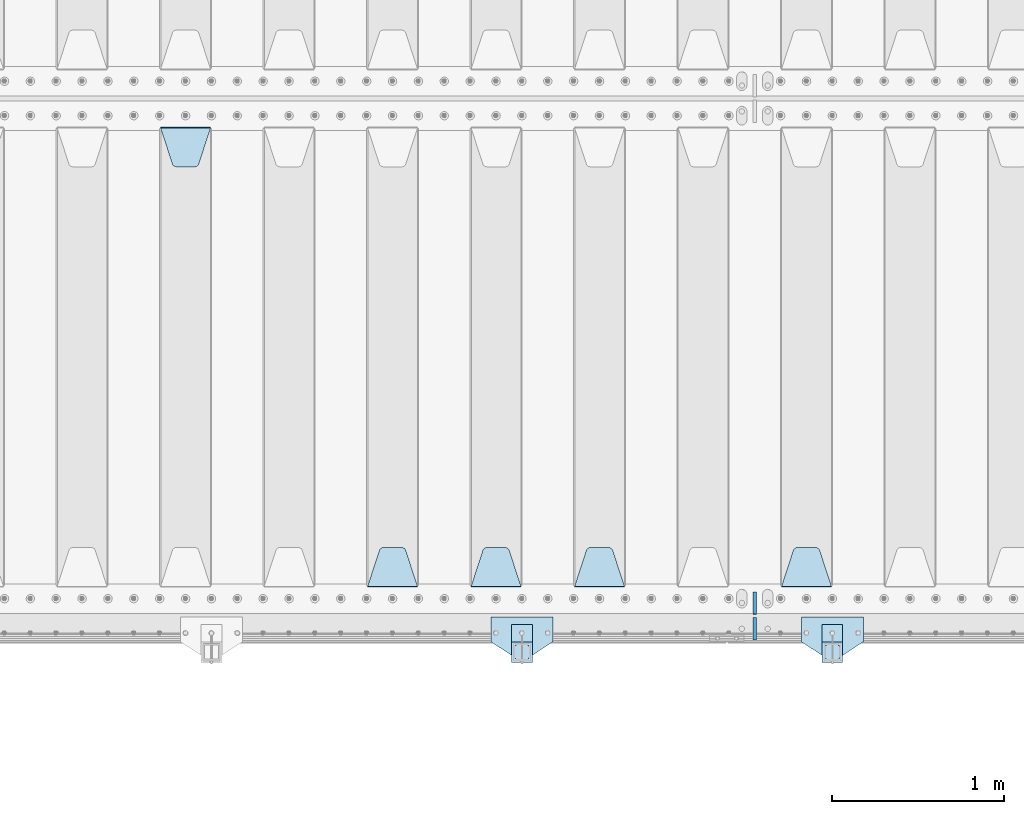
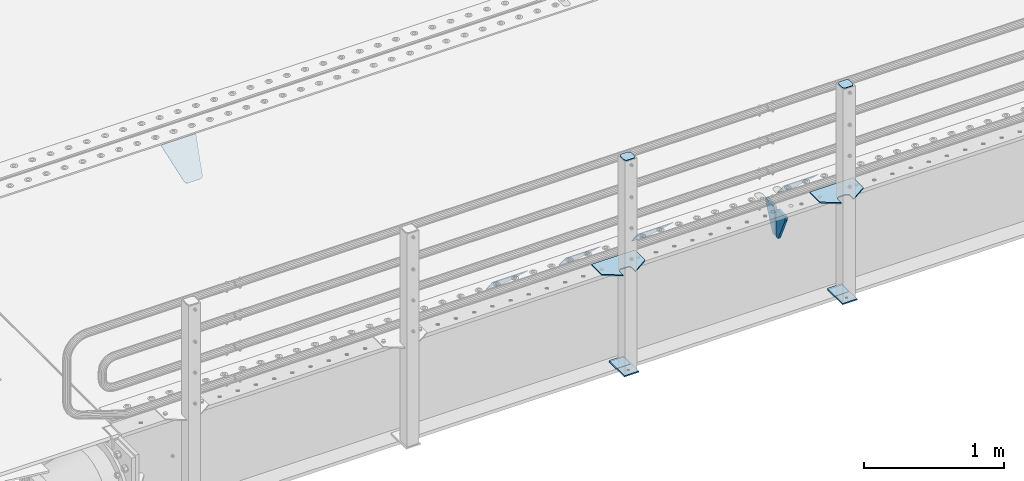
# One storey, part 198 of 247: 15 plates.
"""IFC2X3 building model written with IfcOpenShell, lengths in millimetres."""

from ifc_helpers import new_model, si_unit, frame, origin_with_axes, place, context, subcontext, project, spatial, faceted_brep, material, type_object, element, save


model = new_model("IFC2X3")

# Units and contexts
model_context = context("Model", 3, precision=1e-05, world=origin_with_axes())
body_context = subcontext(model_context, "Body", "Model", "MODEL_VIEW")
ifc_project = project(units=[si_unit("LENGTHUNIT", "METRE", prefix="MILLI"), si_unit("AREAUNIT", "SQUARE_METRE"), si_unit("VOLUMEUNIT", "CUBIC_METRE"), si_unit("MASSUNIT", "GRAM", prefix="KILO"), si_unit("TIMEUNIT", "SECOND"), si_unit("PLANEANGLEUNIT", "RADIAN"), si_unit("SOLIDANGLEUNIT", "STERADIAN"), si_unit("THERMODYNAMICTEMPERATUREUNIT", "DEGREE_CELSIUS"), si_unit("LUMINOUSINTENSITYUNIT", "LUMEN")], contexts=[model_context])

# Site, building, storey
site_placement = place(None, origin_with_axes())
site = spatial("IfcSite", under=ifc_project, at=site_placement, CompositionType="ELEMENT")
building_placement = place(site_placement, origin_with_axes())
building = spatial("IfcBuilding", under=site, at=building_placement, Name="Standard", CompositionType="ELEMENT")
storey_placement = place(building_placement, origin_with_axes())
storey = spatial("IfcBuildingStorey", under=building, at=storey_placement, Name="Undefined", CompositionType="ELEMENT", Elevation=0.0)

# Plates
ifc_material_1 = material(Name="STEEL/S355N")
plate_type_1 = type_object("IfcPlateType", PredefinedType="NOTDEFINED")
plate_1_placement = place(storey_placement, frame((5945.0, 168.232233047034, -1.76776695296758), z_axis=(0.0, 0.707106781186548, -0.707106781186547), x_axis=(-1.0, 0.0, 0.0)))
element("IfcPlate", 1, at=plate_1_placement, inside=storey, type_object=plate_type_1, material=ifc_material_1, context=body_context, shape_type="Brep", body=[
    faceted_brep([(0.0, -2.49999999999909, 0.0), (69.345504679477, -2.5, 300.17173142483), (69.345504679477, 2.50000000000091, 300.171731424831), (0.0, 2.5, -9.09494701772928e-13), (70.9274061199576, -2.5, 304.897442415399), (70.9274061199576, 2.50000000000091, 304.8974424154), (73.3818627772307, -2.49999999999909, 309.234538108527), (73.3818627772307, 2.5, 309.234538108526), (76.6187032999551, -2.5, 313.023683126102), (76.6187032999551, 2.50000000000091, 313.023683126102), (80.5190132704993, -2.49999999999909, 316.125672595371), (80.5190132704993, 2.50000000000091, 316.125672595372), (84.9395038596849, -2.49999999999909, 318.426546230476), (84.9395038596849, 2.5, 318.426546230475), (89.7177759439219, -2.5, 319.841774983274), (89.7177759439219, 2.50000000000091, 319.841774983275), (94.678286292652, -2.5, 320.319366455077), (94.678286292652, 2.50000000000091, 320.319366455077), (195.321713707348, -2.5, 320.319366455077), (195.321713707348, 2.50000000000091, 320.319366455077), (200.282224056078, -2.5, 319.841774983274), (200.282224056078, 2.50000000000091, 319.841774983275), (205.060496140315, -2.5, 318.426546230475), (205.060496140315, 2.5, 318.426546230474), (209.480986729501, -2.49999999999818, 316.12567259537), (209.480986729501, 2.50000000000091, 316.12567259537), (213.381296700045, -2.5, 313.023683126101), (213.381296700045, 2.50000000000091, 313.023683126101), (216.618137222769, -2.5, 309.234538108525), (216.618137222769, 2.5, 309.234538108525), (219.072593880042, -2.49999999999909, 304.897442415398), (219.072593880042, 2.5, 304.897442415398), (220.654495320523, -2.5, 300.17173142483), (220.654495320523, 2.50000000000091, 300.171731424831), (290.0, -2.49999999999909, 0.0), (290.0, 2.5, -9.09494701772928e-13)], [[[0, 1, 2, 3]], [[1, 4, 5, 2]], [[4, 6, 7, 5]], [[6, 8, 9, 7]], [[8, 10, 11, 9]], [[10, 12, 13, 11]], [[12, 14, 15, 13]], [[14, 16, 17, 15]], [[16, 18, 19, 17]], [[18, 20, 21, 19]], [[20, 22, 23, 21]], [[22, 24, 25, 23]], [[24, 26, 27, 25]], [[26, 28, 29, 27]], [[28, 30, 31, 29]], [[30, 32, 33, 31]], [[32, 34, 35, 33]], [[34, 0, 3, 35]], [[5, 7, 9, 11, 13, 15, 17, 19, 21, 23, 25, 27, 29, 31, 33, 35, 3, 2]], [[34, 32, 30, 28, 26, 24, 22, 20, 18, 16, 14, 12, 10, 8, 6, 4, 1, 0]]]),
])
plate_2_placement = place(storey_placement, frame((4745.0, 168.232233047034, -1.76776695296758), z_axis=(0.0, 0.707106781186548, -0.707106781186547), x_axis=(-1.0, 0.0, 0.0)))
element("IfcPlate", 2, at=plate_2_placement, inside=storey, type_object=plate_type_1, material=ifc_material_1, context=body_context, shape_type="Brep", body=[
    faceted_brep([(0.0, -2.49999999999909, 0.0), (69.345504679477, -2.5, 300.17173142483), (69.345504679477, 2.50000000000091, 300.171731424831), (0.0, 2.5, -9.09494701772928e-13), (70.9274061199576, -2.5, 304.897442415399), (70.9274061199576, 2.50000000000091, 304.8974424154), (73.3818627772307, -2.49999999999909, 309.234538108527), (73.3818627772307, 2.5, 309.234538108526), (76.6187032999551, -2.5, 313.023683126102), (76.6187032999551, 2.50000000000091, 313.023683126102), (80.5190132704993, -2.49999999999909, 316.125672595371), (80.5190132704993, 2.50000000000091, 316.125672595372), (84.9395038596849, -2.49999999999909, 318.426546230476), (84.9395038596849, 2.5, 318.426546230475), (89.7177759439219, -2.5, 319.841774983274), (89.7177759439219, 2.50000000000091, 319.841774983275), (94.678286292652, -2.5, 320.319366455077), (94.678286292652, 2.50000000000091, 320.319366455077), (195.321713707348, -2.5, 320.319366455077), (195.321713707348, 2.50000000000091, 320.319366455077), (200.282224056078, -2.5, 319.841774983274), (200.282224056078, 2.50000000000091, 319.841774983275), (205.060496140315, -2.5, 318.426546230475), (205.060496140315, 2.5, 318.426546230474), (209.480986729501, -2.49999999999818, 316.12567259537), (209.480986729501, 2.50000000000091, 316.12567259537), (213.381296700045, -2.5, 313.023683126101), (213.381296700045, 2.50000000000091, 313.023683126101), (216.618137222769, -2.5, 309.234538108525), (216.618137222769, 2.5, 309.234538108525), (219.072593880042, -2.49999999999909, 304.897442415398), (219.072593880042, 2.5, 304.897442415398), (220.654495320523, -2.5, 300.17173142483), (220.654495320523, 2.50000000000091, 300.171731424831), (290.0, -2.49999999999909, 0.0), (290.0, 2.5, -9.09494701772928e-13)], [[[0, 1, 2, 3]], [[1, 4, 5, 2]], [[4, 6, 7, 5]], [[6, 8, 9, 7]], [[8, 10, 11, 9]], [[10, 12, 13, 11]], [[12, 14, 15, 13]], [[14, 16, 17, 15]], [[16, 18, 19, 17]], [[18, 20, 21, 19]], [[20, 22, 23, 21]], [[22, 24, 25, 23]], [[24, 26, 27, 25]], [[26, 28, 29, 27]], [[28, 30, 31, 29]], [[30, 32, 33, 31]], [[32, 34, 35, 33]], [[34, 0, 3, 35]], [[5, 7, 9, 11, 13, 15, 17, 19, 21, 23, 25, 27, 29, 31, 33, 35, 3, 2]], [[34, 32, 30, 28, 26, 24, 22, 20, 18, 16, 14, 12, 10, 8, 6, 4, 1, 0]]]),
])
plate_3_placement = place(storey_placement, frame((4145.0, 168.232233047034, -1.76776695296758), z_axis=(0.0, 0.707106781186548, -0.707106781186547), x_axis=(-1.0, 0.0, 0.0)))
element("IfcPlate", 3, at=plate_3_placement, inside=storey, type_object=plate_type_1, material=ifc_material_1, context=body_context, shape_type="Brep", body=[
    faceted_brep([(0.0, -2.49999999999909, 0.0), (69.345504679477, -2.5, 300.17173142483), (69.345504679477, 2.50000000000091, 300.171731424831), (0.0, 2.5, -9.09494701772928e-13), (70.9274061199576, -2.5, 304.897442415399), (70.9274061199576, 2.50000000000091, 304.8974424154), (73.3818627772307, -2.49999999999909, 309.234538108527), (73.3818627772307, 2.5, 309.234538108526), (76.6187032999551, -2.5, 313.023683126102), (76.6187032999551, 2.50000000000091, 313.023683126102), (80.5190132704993, -2.49999999999909, 316.125672595371), (80.5190132704993, 2.50000000000091, 316.125672595372), (84.9395038596849, -2.49999999999909, 318.426546230476), (84.9395038596849, 2.5, 318.426546230475), (89.7177759439219, -2.5, 319.841774983274), (89.7177759439219, 2.50000000000091, 319.841774983275), (94.678286292652, -2.5, 320.319366455077), (94.678286292652, 2.50000000000091, 320.319366455077), (195.321713707348, -2.5, 320.319366455077), (195.321713707348, 2.50000000000091, 320.319366455077), (200.282224056078, -2.5, 319.841774983274), (200.282224056078, 2.50000000000091, 319.841774983275), (205.060496140315, -2.5, 318.426546230475), (205.060496140315, 2.5, 318.426546230474), (209.480986729501, -2.49999999999818, 316.12567259537), (209.480986729501, 2.50000000000091, 316.12567259537), (213.381296700045, -2.5, 313.023683126101), (213.381296700045, 2.50000000000091, 313.023683126101), (216.618137222769, -2.5, 309.234538108525), (216.618137222769, 2.5, 309.234538108525), (219.072593880042, -2.49999999999909, 304.897442415398), (219.072593880042, 2.5, 304.897442415398), (220.654495320523, -2.5, 300.17173142483), (220.654495320523, 2.50000000000091, 300.171731424831), (290.0, -2.49999999999909, 0.0), (290.0, 2.5, -9.09494701772928e-13)], [[[0, 1, 2, 3]], [[1, 4, 5, 2]], [[4, 6, 7, 5]], [[6, 8, 9, 7]], [[8, 10, 11, 9]], [[10, 12, 13, 11]], [[12, 14, 15, 13]], [[14, 16, 17, 15]], [[16, 18, 19, 17]], [[18, 20, 21, 19]], [[20, 22, 23, 21]], [[22, 24, 25, 23]], [[24, 26, 27, 25]], [[26, 28, 29, 27]], [[28, 30, 31, 29]], [[30, 32, 33, 31]], [[32, 34, 35, 33]], [[34, 0, 3, 35]], [[5, 7, 9, 11, 13, 15, 17, 19, 21, 23, 25, 27, 29, 31, 33, 35, 3, 2]], [[34, 32, 30, 28, 26, 24, 22, 20, 18, 16, 14, 12, 10, 8, 6, 4, 1, 0]]]),
])
plate_4_placement = place(storey_placement, frame((3545.0, 168.232233047034, -1.76776695296758), z_axis=(0.0, 0.707106781186548, -0.707106781186547), x_axis=(-1.0, 0.0, 0.0)))
element("IfcPlate", 4, at=plate_4_placement, inside=storey, type_object=plate_type_1, material=ifc_material_1, context=body_context, shape_type="Brep", body=[
    faceted_brep([(0.0, -2.49999999999909, 0.0), (69.345504679477, -2.5, 300.17173142483), (69.345504679477, 2.50000000000091, 300.171731424831), (0.0, 2.5, -9.09494701772928e-13), (70.9274061199576, -2.5, 304.897442415399), (70.9274061199576, 2.50000000000091, 304.8974424154), (73.3818627772307, -2.49999999999909, 309.234538108527), (73.3818627772307, 2.5, 309.234538108526), (76.6187032999551, -2.5, 313.023683126102), (76.6187032999551, 2.50000000000091, 313.023683126102), (80.5190132704993, -2.49999999999909, 316.125672595371), (80.5190132704993, 2.50000000000091, 316.125672595372), (84.9395038596849, -2.49999999999909, 318.426546230476), (84.9395038596849, 2.5, 318.426546230475), (89.7177759439219, -2.5, 319.841774983274), (89.7177759439219, 2.50000000000091, 319.841774983275), (94.678286292652, -2.5, 320.319366455077), (94.678286292652, 2.50000000000091, 320.319366455077), (195.321713707348, -2.5, 320.319366455077), (195.321713707348, 2.50000000000091, 320.319366455077), (200.282224056078, -2.5, 319.841774983274), (200.282224056078, 2.50000000000091, 319.841774983275), (205.060496140315, -2.5, 318.426546230475), (205.060496140315, 2.5, 318.426546230474), (209.480986729501, -2.49999999999818, 316.12567259537), (209.480986729501, 2.50000000000091, 316.12567259537), (213.381296700045, -2.5, 313.023683126101), (213.381296700045, 2.50000000000091, 313.023683126101), (216.618137222769, -2.5, 309.234538108525), (216.618137222769, 2.5, 309.234538108525), (219.072593880042, -2.49999999999909, 304.897442415398), (219.072593880042, 2.5, 304.897442415398), (220.654495320523, -2.5, 300.17173142483), (220.654495320523, 2.50000000000091, 300.171731424831), (290.0, -2.49999999999909, 0.0), (290.0, 2.5, -9.09494701772928e-13)], [[[0, 1, 2, 3]], [[1, 4, 5, 2]], [[4, 6, 7, 5]], [[6, 8, 9, 7]], [[8, 10, 11, 9]], [[10, 12, 13, 11]], [[12, 14, 15, 13]], [[14, 16, 17, 15]], [[16, 18, 19, 17]], [[18, 20, 21, 19]], [[20, 22, 23, 21]], [[22, 24, 25, 23]], [[24, 26, 27, 25]], [[26, 28, 29, 27]], [[28, 30, 31, 29]], [[30, 32, 33, 31]], [[32, 34, 35, 33]], [[34, 0, 3, 35]], [[5, 7, 9, 11, 13, 15, 17, 19, 21, 23, 25, 27, 29, 31, 33, 35, 3, 2]], [[34, 32, 30, 28, 26, 24, 22, 20, 18, 16, 14, 12, 10, 8, 6, 4, 1, 0]]]),
])
plate_5_placement = place(storey_placement, frame((2055.0, 2831.76776695594, -1.767766952965), z_axis=(0.0, -0.707106781186548, -0.707106781186547), x_axis=(1.0, 0.0, 0.0)))
element("IfcPlate", 5, at=plate_5_placement, inside=storey, type_object=plate_type_1, material=ifc_material_1, context=body_context, shape_type="Brep", body=[
    faceted_brep([(0.0, -2.49999999999909, 0.0), (69.345504679477, -2.5, 300.17173142483), (69.345504679477, 2.50000000000091, 300.171731424831), (0.0, 2.5, -9.09494701772928e-13), (70.9274061199576, -2.5, 304.897442415399), (70.9274061199576, 2.50000000000091, 304.8974424154), (73.3818627772307, -2.49999999999909, 309.234538108527), (73.3818627772307, 2.5, 309.234538108526), (76.6187032999551, -2.5, 313.023683126102), (76.6187032999551, 2.50000000000091, 313.023683126102), (80.5190132704993, -2.49999999999909, 316.125672595371), (80.5190132704993, 2.50000000000091, 316.125672595372), (84.9395038596849, -2.49999999999909, 318.426546230476), (84.9395038596849, 2.5, 318.426546230475), (89.7177759439219, -2.5, 319.841774983274), (89.7177759439219, 2.50000000000091, 319.841774983275), (94.678286292652, -2.5, 320.319366455077), (94.678286292652, 2.50000000000091, 320.319366455077), (195.321713707348, -2.5, 320.319366455077), (195.321713707348, 2.50000000000091, 320.319366455077), (200.282224056078, -2.5, 319.841774983274), (200.282224056078, 2.50000000000091, 319.841774983275), (205.060496140315, -2.5, 318.426546230475), (205.060496140315, 2.5, 318.426546230474), (209.480986729501, -2.49999999999818, 316.12567259537), (209.480986729501, 2.50000000000091, 316.12567259537), (213.381296700045, -2.5, 313.023683126101), (213.381296700045, 2.50000000000091, 313.023683126101), (216.618137222769, -2.5, 309.234538108525), (216.618137222769, 2.5, 309.234538108525), (219.072593880042, -2.49999999999909, 304.897442415398), (219.072593880042, 2.5, 304.897442415398), (220.654495320523, -2.5, 300.17173142483), (220.654495320523, 2.50000000000091, 300.171731424831), (290.0, -2.49999999999909, 0.0), (290.0, 2.5, -9.09494701772928e-13)], [[[0, 1, 2, 3]], [[1, 4, 5, 2]], [[4, 6, 7, 5]], [[6, 8, 9, 7]], [[8, 10, 11, 9]], [[10, 12, 13, 11]], [[12, 14, 15, 13]], [[14, 16, 17, 15]], [[16, 18, 19, 17]], [[18, 20, 21, 19]], [[20, 22, 23, 21]], [[22, 24, 25, 23]], [[24, 26, 27, 25]], [[26, 28, 29, 27]], [[28, 30, 31, 29]], [[30, 32, 33, 31]], [[32, 34, 35, 33]], [[34, 0, 3, 35]], [[5, 7, 9, 11, 13, 15, 17, 19, 21, 23, 25, 27, 29, 31, 33, 35, 3, 2]], [[34, 32, 30, 28, 26, 24, 22, 20, 18, 16, 14, 12, 10, 8, 6, 4, 1, 0]]]),
])
plate_type_2 = type_object("IfcPlateType", PredefinedType="NOTDEFINED")
for number, where, z_axis, x_axis in (
    (6, (5500.0, 140.0, -30.0), (0.0, 0.0, -1.0), (0.0, -0.999999999999548, -9.5100000000016e-07)),
    (7, (5500.0, -140.0, -30.0), (0.0, 0.0, -1.0), (0.0, 1.0, 0.0)),
):
    element("IfcPlate", number, at=place(storey_placement, frame(where, z_axis=z_axis, x_axis=x_axis)), inside=storey, type_object=plate_type_2, material=ifc_material_1, context=body_context, shape_type="Brep", body=[
        faceted_brep([(-5.6843418860808e-14, -9.99999999999989, 3.5527136788005e-15), (0.0, -10.0, 30.0), (0.0, 10.0, 30.0), (-5.6843418860808e-14, 10.0000000000001, 3.5527136788005e-15), (102.0, -10.0, 250.0), (102.0, 10.0, 250.0), (132.0, -10.0, 250.0), (132.0, 10.0, 250.0), (132.0, -10.0, 30.0), (132.0, 10.0, 30.0), (131.544232590366, -10.0, 24.790554669992), (131.544232590366, 10.0, 24.790554669992), (130.190778623577, -10.0, 19.7393957002299), (130.190778623577, 10.0, 19.7393957002299), (127.980762113533, -10.0, 15.0), (127.980762113533, 10.0, 15.0), (124.981333293569, -10.0, 10.7163717094038), (124.981333293569, 10.0, 10.7163717094038), (121.283628290596, -10.0, 7.01866670643062), (121.283628290596, 10.0, 7.01866670643062), (117.0, -10.0, 4.01923788646684), (117.0, 10.0, 4.01923788646684), (112.26060429977, -10.0, 1.80922137642278), (112.26060429977, 10.0, 1.80922137642278), (107.209445330008, -10.0, 0.455767409633722), (107.209445330008, 10.0, 0.455767409633722), (102.0, -10.0, 0.0), (102.0, 10.0, 0.0)], [[[0, 1, 2, 3]], [[1, 4, 5, 2]], [[4, 6, 7, 5]], [[6, 8, 9, 7]], [[8, 10, 11, 9]], [[10, 12, 13, 11]], [[12, 14, 15, 13]], [[14, 16, 17, 15]], [[16, 18, 19, 17]], [[18, 20, 21, 19]], [[20, 22, 23, 21]], [[22, 24, 25, 23]], [[24, 26, 27, 25]], [[26, 0, 3, 27]], [[5, 7, 9, 11, 13, 15, 17, 19, 21, 23, 25, 27, 3, 2]], [[26, 24, 22, 20, 18, 16, 14, 12, 10, 8, 6, 4, 1, 0]]]),
    ])
ifc_material_2 = material(Name="STEEL/S355J2")
plate_type_3 = type_object("IfcPlateType", PredefinedType="NOTDEFINED")
plate_6_placement = place(storey_placement, frame((6130.0, -4.99999999999636, 5.00000000004911), z_axis=(0.0, -0.999999999999548, -9.5100000000016e-07), x_axis=(-1.0, 0.0, 0.0)))
element("IfcPlate", 8, at=plate_6_placement, inside=storey, type_object=plate_type_3, material=ifc_material_2, context=body_context, shape_type="Brep", body=[
    faceted_brep([(9.04219632502645e-09, -5.00000000143385, -2.89173840428703e-09), (2.31396552408114e-06, -5.0, 145.0), (2.31396552408114e-06, 5.0, 145.0), (7.66340235713869e-09, 4.99999999856618, -2.89173840428703e-09), (130.0, -5.0, 230.0), (130.0, 5.0, 230.0), (130.0, -5.0, 180.0), (130.0, 5.0, 180.0), (130.48036798992, -5.0, 175.122741949597), (130.48036798992, 5.0, 175.122741949597), (131.903011687218, -5.0, 170.432914190873), (131.903011687218, 5.0, 170.432914190873), (134.213259692437, -5.0, 166.11074417451), (134.213259692437, 5.0, 166.11074417451), (137.322330470337, -5.0, 162.322330470337), (137.322330470337, 5.0, 162.322330470337), (141.11074417451, -5.0, 159.213259692437), (141.11074417451, 5.0, 159.213259692437), (145.432914190873, -5.0, 156.903011687218), (145.432914190873, 5.0, 156.903011687218), (150.122741949597, -5.0, 155.48036798992), (150.122741949597, 5.0, 155.48036798992), (155.0, -5.0, 155.0), (155.0, 5.0, 155.0), (205.0, -5.0, 155.0), (205.0, 5.0, 155.0), (209.877258050403, -5.0, 155.48036798992), (209.877258050403, 5.0, 155.48036798992), (214.567085809127, -5.0, 156.903011687218), (214.567085809127, 5.0, 156.903011687218), (218.88925582549, -5.0, 159.213259692437), (218.88925582549, 5.0, 159.213259692437), (222.677669529663, -5.0, 162.322330470337), (222.677669529663, 5.0, 162.322330470337), (225.786740307563, -5.0, 166.11074417451), (225.786740307563, 5.0, 166.11074417451), (228.096988312782, -5.0, 170.432914190873), (228.096988312782, 5.0, 170.432914190873), (229.51963201008, -5.0, 175.122741949597), (229.51963201008, 5.0, 175.122741949597), (230.0, -5.0, 180.0), (230.0, 5.0, 180.0), (230.0, -5.0, 230.0), (230.0, 5.0, 230.0), (360.0, -5.0, 145.0), (360.0, 5.0, 145.0), (360.0, -5.0, -7.27595761418343e-12), (360.0, 5.0, -7.27595761418343e-12)], [[[0, 1, 2, 3]], [[1, 4, 5, 2]], [[4, 6, 7, 5]], [[6, 8, 9, 7]], [[8, 10, 11, 9]], [[10, 12, 13, 11]], [[12, 14, 15, 13]], [[14, 16, 17, 15]], [[16, 18, 19, 17]], [[18, 20, 21, 19]], [[20, 22, 23, 21]], [[22, 24, 25, 23]], [[24, 26, 27, 25]], [[26, 28, 29, 27]], [[28, 30, 31, 29]], [[30, 32, 33, 31]], [[32, 34, 35, 33]], [[34, 36, 37, 35]], [[36, 38, 39, 37]], [[38, 40, 41, 39]], [[40, 42, 43, 41]], [[42, 44, 45, 43]], [[44, 46, 47, 45]], [[46, 0, 3, 47]], [[5, 7, 9, 11, 13, 15, 17, 19, 21, 23, 25, 27, 29, 31, 33, 35, 37, 39, 41, 43, 45, 47, 3, 2]], [[46, 44, 42, 40, 38, 36, 34, 32, 30, 28, 26, 24, 22, 20, 18, 16, 14, 12, 10, 8, 6, 4, 1, 0]]]),
])
plate_7_placement = place(storey_placement, frame((4330.0, -4.99999999999636, 5.00000000004911), z_axis=(0.0, -0.999999999999548, -9.5100000000016e-07), x_axis=(-1.0, 0.0, 0.0)))
element("IfcPlate", 9, at=plate_7_placement, inside=storey, type_object=plate_type_3, material=ifc_material_2, context=body_context, shape_type="Brep", body=[
    faceted_brep([(9.04219632502645e-09, -5.00000000143385, -2.89173840428703e-09), (2.31396552408114e-06, -5.0, 145.0), (2.31396552408114e-06, 5.0, 145.0), (7.66340235713869e-09, 4.99999999856618, -2.89173840428703e-09), (130.0, -5.0, 230.0), (130.0, 5.0, 230.0), (130.0, -5.0, 180.0), (130.0, 5.0, 180.0), (130.48036798992, -5.0, 175.122741949597), (130.48036798992, 5.0, 175.122741949597), (131.903011687218, -5.0, 170.432914190873), (131.903011687218, 5.0, 170.432914190873), (134.213259692437, -5.0, 166.11074417451), (134.213259692437, 5.0, 166.11074417451), (137.322330470337, -5.0, 162.322330470337), (137.322330470337, 5.0, 162.322330470337), (141.11074417451, -5.0, 159.213259692437), (141.11074417451, 5.0, 159.213259692437), (145.432914190873, -5.0, 156.903011687218), (145.432914190873, 5.0, 156.903011687218), (150.122741949597, -5.0, 155.48036798992), (150.122741949597, 5.0, 155.48036798992), (155.0, -5.0, 155.0), (155.0, 5.0, 155.0), (205.0, -5.0, 155.0), (205.0, 5.0, 155.0), (209.877258050403, -5.0, 155.48036798992), (209.877258050403, 5.0, 155.48036798992), (214.567085809127, -5.0, 156.903011687218), (214.567085809127, 5.0, 156.903011687218), (218.88925582549, -5.0, 159.213259692437), (218.88925582549, 5.0, 159.213259692437), (222.677669529663, -5.0, 162.322330470337), (222.677669529663, 5.0, 162.322330470337), (225.786740307563, -5.0, 166.11074417451), (225.786740307563, 5.0, 166.11074417451), (228.096988312782, -5.0, 170.432914190873), (228.096988312782, 5.0, 170.432914190873), (229.51963201008, -5.0, 175.122741949597), (229.51963201008, 5.0, 175.122741949597), (230.0, -5.0, 180.0), (230.0, 5.0, 180.0), (230.0, -5.0, 230.0), (230.0, 5.0, 230.0), (360.0, -5.0, 145.0), (360.0, 5.0, 145.0), (360.0, -5.0, -7.27595761418343e-12), (360.0, 5.0, -7.27595761418343e-12)], [[[0, 1, 2, 3]], [[1, 4, 5, 2]], [[4, 6, 7, 5]], [[6, 8, 9, 7]], [[8, 10, 11, 9]], [[10, 12, 13, 11]], [[12, 14, 15, 13]], [[14, 16, 17, 15]], [[16, 18, 19, 17]], [[18, 20, 21, 19]], [[20, 22, 23, 21]], [[22, 24, 25, 23]], [[24, 26, 27, 25]], [[26, 28, 29, 27]], [[28, 30, 31, 29]], [[30, 32, 33, 31]], [[32, 34, 35, 33]], [[34, 36, 37, 35]], [[36, 38, 39, 37]], [[38, 40, 41, 39]], [[40, 42, 43, 41]], [[42, 44, 45, 43]], [[44, 46, 47, 45]], [[46, 0, 3, 47]], [[5, 7, 9, 11, 13, 15, 17, 19, 21, 23, 25, 27, 29, 31, 33, 35, 37, 39, 41, 43, 45, 47, 3, 2]], [[46, 44, 42, 40, 38, 36, 34, 32, 30, 28, 26, 24, 22, 20, 18, 16, 14, 12, 10, 8, 6, 4, 1, 0]]]),
])
plate_type_4 = type_object("IfcPlateType", PredefinedType="NOTDEFINED")
for number, where, z_axis, x_axis in (
    (10, (6009.99999999986, -50.0000000002074, -850.000000000002), (0.0, -0.999999999999548, -9.5100000000016e-07), (-1.0, 0.0, 0.0)),
    (11, (4209.99999999986, -50.0000000002074, -850.000000000002), (0.0, -0.999999999999548, -9.5100000000016e-07), (-1.0, 0.0, 0.0)),
):
    element("IfcPlate", number, at=place(storey_placement, frame(where, z_axis=z_axis, x_axis=x_axis)), inside=storey, type_object=plate_type_4, material=ifc_material_2, context=body_context, shape_type="Brep", body=[
        faceted_brep([(53.6360389691836, -5.0, 176.363961030469), (53.6360389691836, 5.0, 176.363961030469), (59.9999999998618, 5.0, 178.999999999791), (59.9999999998618, -5.0, 178.999999999791), (66.3639610305399, 5.0, 176.363961030469), (66.3639610305399, -5.0, 176.363961030469), (68.9999999998618, 5.0, 169.999999999791), (68.9999999998618, -5.0, 169.999999999791), (66.3639610305399, 5.0, 163.636038969113), (66.3639610305399, -5.0, 163.636038969113), (59.9999999998618, 5.0, 160.999999999791), (59.9999999998618, -5.0, 160.999999999791), (53.6360389691836, 5.0, 163.636038969113), (53.6360389691836, -5.0, 163.636038969113), (50.9999999998618, 5.0, 169.999999999791), (50.9999999998618, -5.0, 169.999999999791), (120.0, -5.0, 0.0), (120.0, -5.0, 220.0), (0.0, -5.0, 220.0), (9.04219632502645e-09, -5.00000000143385, -2.89173840428703e-09), (7.66340235713869e-09, 4.99999999856618, -2.89173840428703e-09), (120.0, 5.0, 0.0), (120.0, 5.0, 220.0), (0.0, 5.0, 220.0)], [[[0, 1, 2, 3]], [[3, 2, 4, 5]], [[5, 4, 6, 7]], [[7, 6, 8, 9]], [[9, 8, 10, 11]], [[11, 10, 12, 13]], [[13, 12, 14, 15]], [[15, 14, 1, 0]], [[16, 17, 18, 19], [11, 13, 15, 0, 3, 5, 7, 9]], [[16, 19, 20, 21]], [[17, 16, 21, 22]], [[18, 17, 22, 23]], [[19, 18, 23, 20]], [[22, 21, 20, 23], [2, 1, 14, 12, 10, 8, 6, 4]]]),
    ])
plate_type_5 = type_object("IfcPlateType", PredefinedType="NOTDEFINED")
plate_8_placement = place(storey_placement, frame((5905.99999999987, -166.000000000207, 1012.50000000001), z_axis=(0.0, -0.999999999999548, -9.5100000000016e-07), x_axis=(1.0, 0.0, 0.0)))
element("IfcPlate", 12, at=plate_8_placement, inside=storey, type_object=plate_type_5, material=ifc_material_2, context=body_context, shape_type="Brep", body=[
    faceted_brep([(0.0, -2.5, 19.0), (0.0, -2.5, 69.0), (0.0, 2.5, 69.0), (0.0, 2.5, 19.0), (0.476369668545885, -2.5, 73.2278977451697), (0.476369668545885, 2.5, 73.2278977451697), (1.88159150985484, -2.5, 77.2437910432327), (1.88159150985484, 2.5, 77.2437910432327), (4.14520183310742, -2.5, 80.8463062353167), (4.14520183310742, 2.5, 80.8463062353167), (7.15369376468334, -2.5, 83.8547981668926), (7.15369376468334, 2.5, 83.8547981668926), (10.7562089567673, -2.5, 86.1184084901452), (10.7562089567673, 2.5, 86.1184084901452), (14.7721022548303, -2.5, 87.5236303314541), (14.7721022548303, 2.5, 87.5236303314541), (19.0, -2.5, 88.0), (19.0, 2.5, 88.0), (69.0, -2.5, 88.0), (69.0, 2.5, 88.0), (73.2278977451697, -2.5, 87.5236303314541), (73.2278977451697, 2.5, 87.5236303314541), (77.2437910432327, -2.5, 86.1184084901452), (77.2437910432327, 2.5, 86.1184084901452), (80.8463062353167, -2.5, 83.8547981668926), (80.8463062353167, 2.5, 83.8547981668926), (83.8547981668926, -2.5, 80.8463062353167), (83.8547981668926, 2.5, 80.8463062353167), (86.1184084901452, -2.5, 77.2437910432327), (86.1184084901452, 2.5, 77.2437910432327), (87.5236303314541, -2.5, 73.2278977451697), (87.5236303314541, 2.5, 73.2278977451697), (88.0, -2.5, 69.0), (88.0, 2.5, 69.0), (88.0, -2.5, 19.0), (88.0, 2.5, 19.0), (87.5236303314541, -2.5, 14.7721022548303), (87.5236303314541, 2.5, 14.7721022548303), (86.1184084901452, -2.5, 10.7562089567673), (86.1184084901452, 2.5, 10.7562089567673), (83.8547981668926, -2.5, 7.15369376468334), (83.8547981668926, 2.5, 7.15369376468334), (80.8463062353167, -2.5, 4.14520183310742), (80.8463062353167, 2.5, 4.14520183310742), (77.2437910432345, -2.5, 1.88159150985484), (77.2437910432345, 2.5, 1.88159150985484), (73.2278977451697, -2.5, 0.476369668545885), (73.2278977451697, 2.5, 0.476369668545885), (69.0, -2.5, 0.0), (69.0, 2.5, 0.0), (19.0, -2.5, 0.0), (19.0, 2.5, 0.0), (14.7721022548303, -2.5, 0.476369668545885), (14.7721022548303, 2.5, 0.476369668545885), (10.7562089567673, -2.5, 1.88159150985484), (10.7562089567673, 2.5, 1.88159150985484), (7.15369376468334, -2.5, 4.14520183310742), (7.15369376468334, 2.5, 4.14520183310742), (4.14520183310742, -2.5, 7.15369376468334), (4.14520183310742, 2.5, 7.15369376468334), (1.88159150985484, -2.5, 10.7562089567673), (1.88159150985484, 2.5, 10.7562089567673), (0.476369668545885, -2.5, 14.7721022548303), (0.476369668545885, 2.5, 14.7721022548303)], [[[0, 1, 2, 3]], [[1, 4, 5, 2]], [[4, 6, 7, 5]], [[6, 8, 9, 7]], [[8, 10, 11, 9]], [[10, 12, 13, 11]], [[12, 14, 15, 13]], [[14, 16, 17, 15]], [[16, 18, 19, 17]], [[18, 20, 21, 19]], [[20, 22, 23, 21]], [[22, 24, 25, 23]], [[24, 26, 27, 25]], [[26, 28, 29, 27]], [[28, 30, 31, 29]], [[30, 32, 33, 31]], [[32, 34, 35, 33]], [[34, 36, 37, 35]], [[36, 38, 39, 37]], [[38, 40, 41, 39]], [[40, 42, 43, 41]], [[42, 44, 45, 43]], [[44, 46, 47, 45]], [[46, 48, 49, 47]], [[48, 50, 51, 49]], [[50, 52, 53, 51]], [[52, 54, 55, 53]], [[54, 56, 57, 55]], [[56, 58, 59, 57]], [[58, 60, 61, 59]], [[60, 62, 63, 61]], [[62, 0, 3, 63]], [[5, 7, 9, 11, 13, 15, 17, 19, 21, 23, 25, 27, 29, 31, 33, 35, 37, 39, 41, 43, 45, 47, 49, 51, 53, 55, 57, 59, 61, 63, 3, 2]], [[62, 60, 58, 56, 54, 52, 50, 48, 46, 44, 42, 40, 38, 36, 34, 32, 30, 28, 26, 24, 22, 20, 18, 16, 14, 12, 10, 8, 6, 4, 1, 0]]]),
])
plate_9_placement = place(storey_placement, frame((4105.99999999987, -166.000000000207, 1012.50000000001), z_axis=(0.0, -0.999999999999548, -9.5100000000016e-07), x_axis=(1.0, 0.0, 0.0)))
element("IfcPlate", 13, at=plate_9_placement, inside=storey, type_object=plate_type_5, material=ifc_material_2, context=body_context, shape_type="Brep", body=[
    faceted_brep([(0.0, -2.5, 19.0), (0.0, -2.5, 69.0), (0.0, 2.5, 69.0), (0.0, 2.5, 19.0), (0.476369668545885, -2.5, 73.2278977451697), (0.476369668545885, 2.5, 73.2278977451697), (1.88159150985484, -2.5, 77.2437910432327), (1.88159150985484, 2.5, 77.2437910432327), (4.14520183310742, -2.5, 80.8463062353167), (4.14520183310742, 2.5, 80.8463062353167), (7.15369376468334, -2.5, 83.8547981668926), (7.15369376468334, 2.5, 83.8547981668926), (10.7562089567673, -2.5, 86.1184084901452), (10.7562089567673, 2.5, 86.1184084901452), (14.7721022548303, -2.5, 87.5236303314541), (14.7721022548303, 2.5, 87.5236303314541), (19.0, -2.5, 88.0), (19.0, 2.5, 88.0), (69.0, -2.5, 88.0), (69.0, 2.5, 88.0), (73.2278977451697, -2.5, 87.5236303314541), (73.2278977451697, 2.5, 87.5236303314541), (77.2437910432327, -2.5, 86.1184084901452), (77.2437910432327, 2.5, 86.1184084901452), (80.8463062353167, -2.5, 83.8547981668926), (80.8463062353167, 2.5, 83.8547981668926), (83.8547981668926, -2.5, 80.8463062353167), (83.8547981668926, 2.5, 80.8463062353167), (86.1184084901452, -2.5, 77.2437910432327), (86.1184084901452, 2.5, 77.2437910432327), (87.5236303314541, -2.5, 73.2278977451697), (87.5236303314541, 2.5, 73.2278977451697), (88.0, -2.5, 69.0), (88.0, 2.5, 69.0), (88.0, -2.5, 19.0), (88.0, 2.5, 19.0), (87.5236303314541, -2.5, 14.7721022548303), (87.5236303314541, 2.5, 14.7721022548303), (86.1184084901452, -2.5, 10.7562089567673), (86.1184084901452, 2.5, 10.7562089567673), (83.8547981668926, -2.5, 7.15369376468334), (83.8547981668926, 2.5, 7.15369376468334), (80.8463062353167, -2.5, 4.14520183310742), (80.8463062353167, 2.5, 4.14520183310742), (77.2437910432345, -2.5, 1.88159150985484), (77.2437910432345, 2.5, 1.88159150985484), (73.2278977451697, -2.5, 0.476369668545885), (73.2278977451697, 2.5, 0.476369668545885), (69.0, -2.5, 0.0), (69.0, 2.5, 0.0), (19.0, -2.5, 0.0), (19.0, 2.5, 0.0), (14.7721022548303, -2.5, 0.476369668545885), (14.7721022548303, 2.5, 0.476369668545885), (10.7562089567673, -2.5, 1.88159150985484), (10.7562089567673, 2.5, 1.88159150985484), (7.15369376468334, -2.5, 4.14520183310742), (7.15369376468334, 2.5, 4.14520183310742), (4.14520183310742, -2.5, 7.15369376468334), (4.14520183310742, 2.5, 7.15369376468334), (1.88159150985484, -2.5, 10.7562089567673), (1.88159150985484, 2.5, 10.7562089567673), (0.476369668545885, -2.5, 14.7721022548303), (0.476369668545885, 2.5, 14.7721022548303)], [[[0, 1, 2, 3]], [[1, 4, 5, 2]], [[4, 6, 7, 5]], [[6, 8, 9, 7]], [[8, 10, 11, 9]], [[10, 12, 13, 11]], [[12, 14, 15, 13]], [[14, 16, 17, 15]], [[16, 18, 19, 17]], [[18, 20, 21, 19]], [[20, 22, 23, 21]], [[22, 24, 25, 23]], [[24, 26, 27, 25]], [[26, 28, 29, 27]], [[28, 30, 31, 29]], [[30, 32, 33, 31]], [[32, 34, 35, 33]], [[34, 36, 37, 35]], [[36, 38, 39, 37]], [[38, 40, 41, 39]], [[40, 42, 43, 41]], [[42, 44, 45, 43]], [[44, 46, 47, 45]], [[46, 48, 49, 47]], [[48, 50, 51, 49]], [[50, 52, 53, 51]], [[52, 54, 55, 53]], [[54, 56, 57, 55]], [[56, 58, 59, 57]], [[58, 60, 61, 59]], [[60, 62, 63, 61]], [[62, 0, 3, 63]], [[5, 7, 9, 11, 13, 15, 17, 19, 21, 23, 25, 27, 29, 31, 33, 35, 37, 39, 41, 43, 45, 47, 49, 51, 53, 55, 57, 59, 61, 63, 3, 2]], [[62, 60, 58, 56, 54, 52, 50, 48, 46, 44, 42, 40, 38, 36, 34, 32, 30, 28, 26, 24, 22, 20, 18, 16, 14, 12, 10, 8, 6, 4, 1, 0]]]),
])
plate_type_6 = type_object("IfcPlateType", PredefinedType="NOTDEFINED")
for number, where, z_axis, x_axis in (
    (14, (6009.99999999986, -50.0000000002074, -857.500000000002), (0.0, -0.999999999999548, -9.5100000000016e-07), (-1.0, 0.0, 0.0)),
    (15, (4209.99999999986, -50.0000000002074, -857.500000000002), (0.0, -0.999999999999548, -9.5100000000016e-07), (-1.0, 0.0, 0.0)),
):
    element("IfcPlate", number, at=place(storey_placement, frame(where, z_axis=z_axis, x_axis=x_axis)), inside=storey, type_object=plate_type_6, material=ifc_material_2, context=body_context, shape_type="Brep", body=[
        faceted_brep([(0.0, -2.49999999999909, 0.0), (0.0, -2.5, 100.0), (0.0, 2.5, 100.0), (0.0, 2.5, -9.09494701772928e-13), (120.0, -2.5, 100.0), (120.0, 2.5, 100.0), (120.0, -2.5, 0.0), (120.0, 2.5, 0.0)], [[[0, 1, 2, 3]], [[1, 4, 5, 2]], [[4, 6, 7, 5]], [[6, 0, 3, 7]], [[5, 7, 3, 2]], [[6, 4, 1, 0]]]),
    ])

save(model, "model.ifc")
